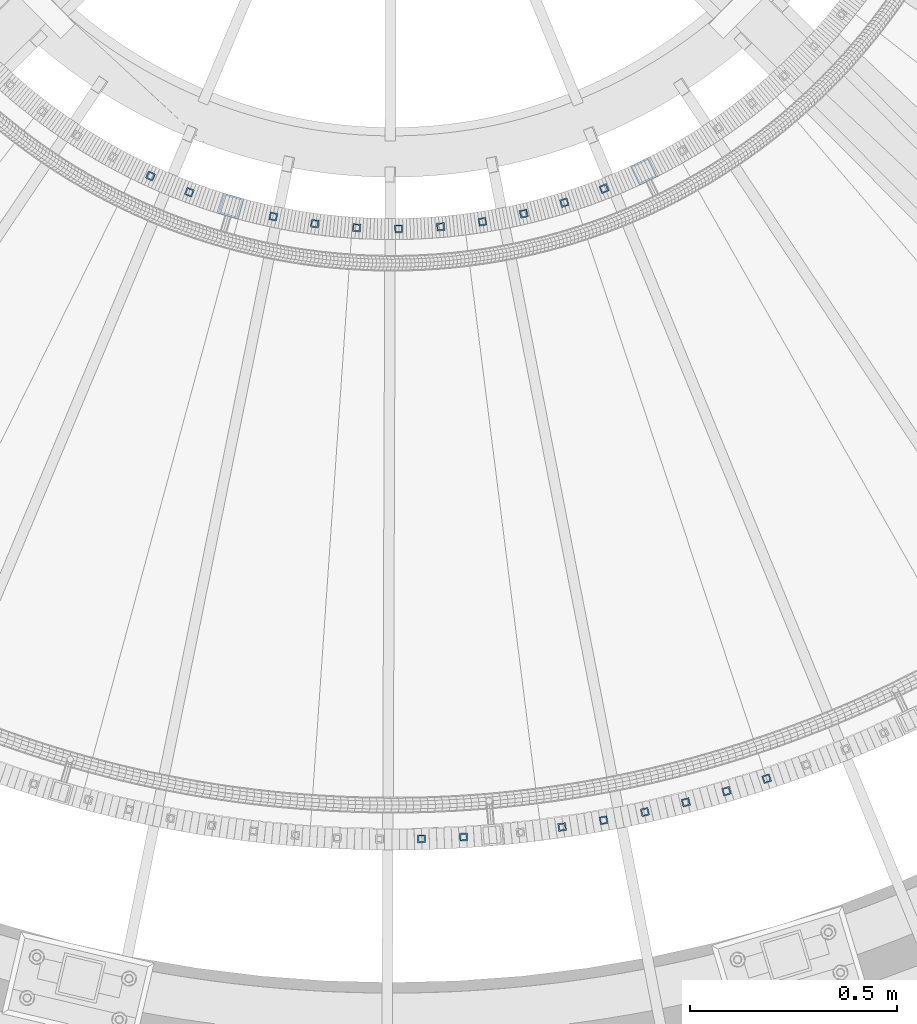
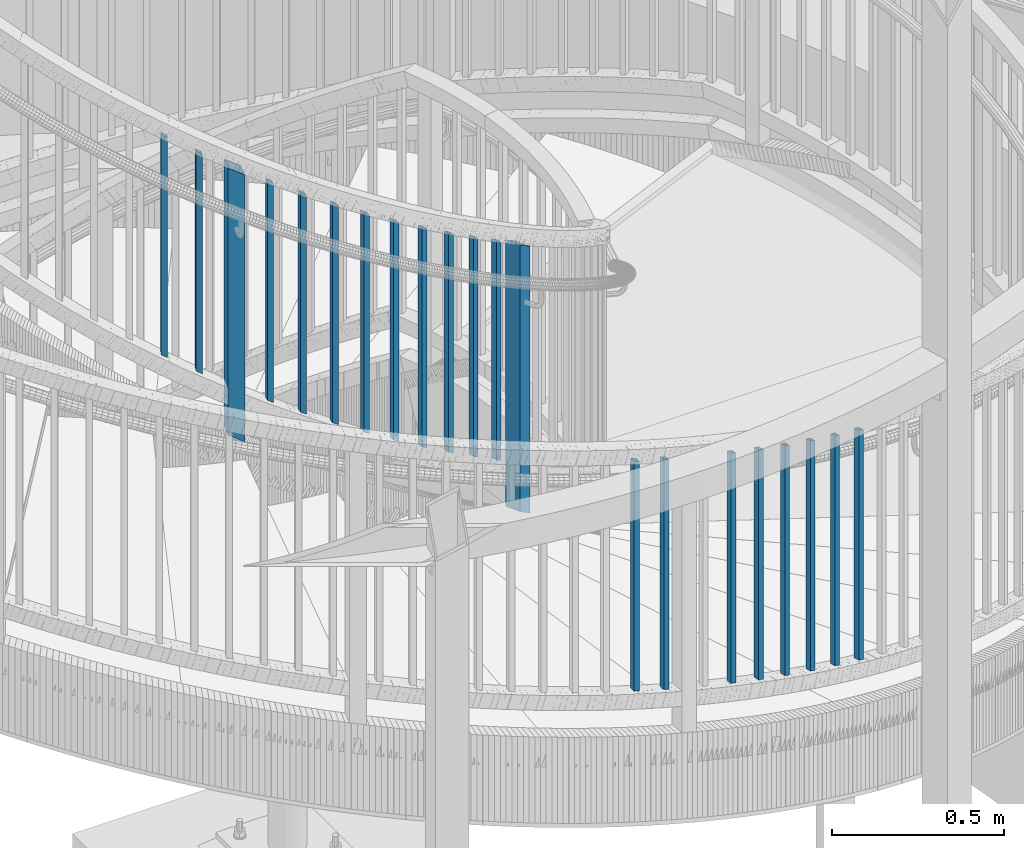
# One storey, part 255 of 975: 21 columns.
"""IFC2X3 building model written with IfcOpenShell, lengths in millimetres."""

from ifc_helpers import new_model, si_unit, frame, origin_with_axes, place, context, subcontext, project, spatial, faceted_brep, material, type_object, element, save


model = new_model("IFC2X3")

# Units and contexts
model_context = context("Model", 3, precision=1e-05, world=origin_with_axes())
body_context = subcontext(model_context, "Body", "Model", "MODEL_VIEW")
ifc_project = project(units=[si_unit("LENGTHUNIT", "METRE", prefix="MILLI"), si_unit("AREAUNIT", "SQUARE_METRE"), si_unit("VOLUMEUNIT", "CUBIC_METRE"), si_unit("MASSUNIT", "GRAM", prefix="KILO"), si_unit("TIMEUNIT", "SECOND"), si_unit("PLANEANGLEUNIT", "RADIAN"), si_unit("SOLIDANGLEUNIT", "STERADIAN"), si_unit("THERMODYNAMICTEMPERATUREUNIT", "DEGREE_CELSIUS"), si_unit("LUMINOUSINTENSITYUNIT", "LUMEN")], contexts=[model_context])

# Site, building, storey
site_placement = place(None, origin_with_axes())
site = spatial("IfcSite", under=ifc_project, at=site_placement, CompositionType="ELEMENT")
building_placement = place(site_placement, origin_with_axes())
building = spatial("IfcBuilding", under=site, at=building_placement, Name="Undefined", CompositionType="ELEMENT")
storey_placement = place(building_placement, origin_with_axes())
storey = spatial("IfcBuildingStorey", under=building, at=storey_placement, Name="Undefined", CompositionType="ELEMENT", Elevation=0.0)

# Columns
ifc_material = material()
column_type_1 = type_object("IfcColumnType", Name="HSS3/4X3/4X.120_TUBES", PredefinedType="NOTDEFINED")
for number, where, z_axis, x_axis, name in (
    (1, (35144.9643289316, 562.901657561375, 3337.39164894143), (0.143220383051681, -0.989690821357119, 0.0), (0.0, 0.0, 1.0), "PICKET"),
    (2, (35245.2335476034, 579.206387144743, 3305.04633694143), (0.178153742922325, -0.984002664570969, 0.0), (0.0, 0.0, 1.0), "PICKET"),
    (3, (35344.8629729798, 599.049220083398, 3272.70102494143), (0.212863934010035, -0.977081852046067, 0.0), (0.0, 0.0, 1.0), "PICKET"),
    (4, (35443.7277997918, 622.405299362534, 3240.35571294143), (0.247307468904138, -0.968937054624411, 0.0), (0.0, 0.0, 1.0), "PICKET"),
    (5, (35541.7041805792, 649.245366941756, 3208.01040094143), (0.281441202939575, -0.959578474793972, 0.0), (0.0, 0.0, 1.0), "PICKET"),
    (6, (35638.6693808336, 679.535800406401, 3175.66508894143), (0.315222376998791, -0.94901783599637, 0.0), (0.0, 0.0, 1.0), "PICKET"),
    (7, (34805.5238669478, 534.391312574778, 3445.4743533963), (0.0249607509979396, -0.999688431917474, 0.0), (0.0, 0.0, 1.0), "PICKET"),
    (8, (34907.0146141472, 538.70181882481, 3413.1290413963), (0.0603219780248401, -0.998178971411025, 0.0), (0.0, 0.0, 1.0), "PICKET"),
):
    element("IfcColumn", number, at=place(storey_placement, frame(where, z_axis=z_axis, x_axis=x_axis)), inside=storey, type_object=column_type_1, material=ifc_material, Name=name, ObjectType="HSS3/4X3/4X.120_TUBES", context=body_context, shape_type="Brep", body=[
        faceted_brep([(48.9778304891588, 6.35000000000036, -6.34999999999854), (44.9444858438005, -6.35000000000582, -6.34999999999127), (858.946568247068, -6.35000000000582, -6.34999999999127), (863.063419332087, 6.35000000000036, -6.34999999999854), (44.9444858438051, -6.35000000000036, 6.35000000000582), (858.946568247072, -6.35000000000036, 6.35000000000582), (48.9778304891634, 6.350000000004, 6.34999999999854), (863.063419332091, 6.350000000004, 6.34999999999854), (49.9861666504976, 9.52499999999964, -9.52500000000146), (49.9861666505039, 9.52500000000691, 9.52499999999418), (864.092632103347, 9.52500000000691, 9.52499999999418), (864.09263210334, 9.52499999999964, -9.52500000000146), (43.9361496824667, -9.52500000000146, 9.52500000001601), (857.917355475819, -9.52500000000146, 9.52500000001601), (43.9361496824599, -9.52500000000691, -9.52499999997963), (857.917355475812, -9.52500000000691, -9.52499999997963)], [[[0, 1, 2, 3]], [[1, 4, 5, 2]], [[4, 6, 7, 5]], [[6, 0, 3, 7]], [[8, 9, 10, 11]], [[9, 12, 13, 10]], [[12, 14, 15, 13]], [[14, 8, 11, 15]], [[13, 15, 11, 10], [5, 7, 3, 2]], [[14, 12, 9, 8], [6, 4, 1, 0]]]),
    ])
for number, where, z_axis, x_axis, name in (
    (9, (34151.3013327036, 2134.41004199642, 3860.961936045), (-0.417534057904537, -0.908661273792259, 0.0), (0.0, 0.0, 1.0), "PICKET"),
    (10, (34245.067153272, 2095.38773828754, 3794.286936045), (-0.350403548031049, -0.936598822082994, 0.0), (0.0, 0.0, 1.0), "PICKET"),
    (11, (34447.7209071227, 2036.58807906212, 3656.38992130595), (-0.205316034013806, -0.978695727065793, 0.0), (0.0, 0.0, 1.0), "PICKET"),
    (12, (34547.8112533657, 2019.36333283445, 3589.71492130595), (-0.133657554974401, -0.991027576810184, 0.0), (0.0, 0.0, 1.0), "PICKET"),
    (13, (34648.8886252272, 2009.45706253692, 3523.03992130595), (-0.0612924279789586, -0.998119851657327, 0.0), (0.0, 0.0, 1.0), "PICKET"),
    (14, (34750.4186254247, 2006.92164273992, 3456.36492130595), (0.0113967529988804, -0.999935054901608, 0.0), (0.0, 0.0, 1.0), "PICKET"),
    (15, (34851.864463624, 2011.77047823845, 3389.68992130595), (0.0840256800377174, -0.996463589447301, 0.0), (0.0, 0.0, 1.0), "PICKET"),
    (16, (34952.6897944563, 2023.97793318084, 3323.80867130595), (0.156210361995181, -0.987723808969559, 0.0), (0.0, 0.0, 1.0), "PICKET"),
    (17, (35052.3615531832, 2043.47946660574, 3257.13367130595), (0.227569156999169, -0.973761920996446, 0.0), (0.0, 0.0, 1.0), "PICKET"),
    (18, (35150.3527740154, 2070.171973671, 3192.04617130595), (0.297724791959052, -0.954651741868698, 0.0), (0.0, 0.0, 1.0), "PICKET"),
    (19, (35246.145376188, 2103.91433077023, 3125.37117130595), (0.366306351865206, -0.930494307657604, 0.0), (0.0, 0.0, 1.0), "PICKET"),
):
    element("IfcColumn", number, at=place(storey_placement, frame(where, z_axis=z_axis, x_axis=x_axis)), inside=storey, type_object=column_type_1, material=ifc_material, Name=name, ObjectType="HSS3/4X3/4X.120_TUBES", context=body_context, shape_type="Brep", body=[
        faceted_brep([(81.3030822565961, 6.34999999999491, -6.34999999997672), (73.0243810963957, -6.34999999999854, -6.35000000000582), (849.31820965341, -6.34999999999854, -6.35000000000582), (857.556470281766, 6.34999999999491, -6.34999999997672), (73.0243810963952, -6.34999999999127, 6.34999999998399), (849.318209653409, -6.34999999999127, 6.34999999998399), (81.3030822565956, 6.35000000000218, 6.34999999999854), (857.556470281765, 6.35000000000218, 6.34999999999854), (83.3727575466464, 9.52499999999054, -9.52499999997235), (83.3727575466455, 9.52500000000509, 9.52500000000146), (859.616035438854, 9.52500000000509, 9.52500000000146), (859.616035438854, 9.52499999999054, -9.52499999997235), (70.9547058063449, -9.5249999999869, 9.52499999997235), (847.25864449632, -9.5249999999869, 9.52499999997235), (70.9547058063458, -9.52500000000146, -9.52499999999418), (847.258644496321, -9.52500000000146, -9.52499999999418)], [[[0, 1, 2, 3]], [[1, 4, 5, 2]], [[4, 6, 7, 5]], [[6, 0, 3, 7]], [[8, 9, 10, 11]], [[9, 12, 13, 10]], [[12, 14, 15, 13]], [[14, 8, 11, 15]], [[13, 15, 11, 10], [5, 7, 3, 2]], [[14, 12, 9, 8], [6, 4, 1, 0]]]),
    ])
column_type_2 = type_object("IfcColumnType", Name="HSS2X2X.188_TUBES", PredefinedType="NOTDEFINED")
column_1_placement = place(storey_placement, frame((35342.9592033706, 2146.06813247641, 2904.07984138255), z_axis=(0.435547032080205, -0.900165975165761, 0.0), x_axis=(0.0, 0.0, 1.0)))
element("IfcColumn", 20, at=column_1_placement, inside=storey, type_object=column_type_2, material=ifc_material, Name="HANDRAIL", ObjectType="HSS2X2X.188_TUBES", context=body_context, shape_type="Brep", body=[
    faceted_brep([(73.8216023003633, 20.6375000000298, -20.6375000000116), (46.7511421721683, -20.6375000000044, -20.6374999999971), (991.653317693376, -20.6375000000044, -20.6374999999971), (1018.78995571227, 20.6375000000298, -20.6375000000116), (46.7511421721192, -20.6375000000262, 20.6375000000116), (991.653317693327, -20.6375000000262, 20.6375000000116), (73.8216023003142, 20.6375000000044, 20.6374999999953), (1018.78995571223, 20.6375000000044, 20.6374999999953), (76.9451169305453, 25.4000000000306, -25.4000000000124), (76.9451169304848, 25.4000000000051, 25.3999999999942), (1021.92110625286, 25.4000000000051, 25.3999999999942), (1021.92110625292, 25.4000000000306, -25.4000000000124), (43.6276275419368, -25.4000000000306, 25.4000000000124), (988.522167152679, -25.4000000000306, 25.4000000000124), (43.6276275419978, -25.4000000000015, -25.399999999996), (988.52216715274, -25.4000000000015, -25.399999999996)], [[[0, 1, 2, 3]], [[1, 4, 5, 2]], [[4, 6, 7, 5]], [[6, 0, 3, 7]], [[8, 9, 10, 11]], [[9, 12, 13, 10]], [[12, 14, 15, 13]], [[14, 8, 11, 15]], [[13, 15, 11, 10], [5, 7, 3, 2]], [[14, 12, 9, 8], [6, 4, 1, 0]]]),
])
column_2_placement = place(storey_placement, frame((34345.2176953613, 2061.93376456903, 3572.63988506017), z_axis=(-0.278655884064232, -0.960391013221376, 0.0), x_axis=(0.0, 0.0, 1.0)))
element("IfcColumn", 21, at=column_2_placement, inside=storey, type_object=column_type_2, material=ifc_material, Name="HANDRAIL", ObjectType="HSS2X2X.188_TUBES", context=body_context, shape_type="Brep", body=[
    faceted_brep([(73.5720581152354, 20.6374999999316, -20.6375000000244), (47.1200722513227, -20.6375000000553, -20.6375000000135), (993.28522860029, -20.6375000000553, -20.6375000000135), (1019.69913264463, 20.6374999999316, -20.6375000000244), (47.1200722513299, -20.6374999999389, 20.6375000000189), (993.285228600298, -20.6374999999389, 20.6375000000189), (73.5720581152427, 20.6375000000444, 20.637500000008), (1019.69913264464, 20.6375000000444, 20.637500000008), (76.6242103303016, 25.3999999999105, -25.4000000000324), (76.6242103303107, 25.400000000056, 25.4000000000106), (1022.7468908036, 25.400000000056, 25.4000000000106), (1022.74689080359, 25.3999999999105, -25.4000000000324), (44.0679200362638, -25.3999999999178, 25.4000000000251), (990.237470441336, -25.3999999999178, 25.4000000000251), (44.0679200362551, -25.4000000000633, -25.400000000016), (990.237470441326, -25.4000000000633, -25.400000000016)], [[[0, 1, 2, 3]], [[1, 4, 5, 2]], [[4, 6, 7, 5]], [[6, 0, 3, 7]], [[8, 9, 10, 11]], [[9, 12, 13, 10]], [[12, 14, 15, 13]], [[14, 8, 11, 15]], [[13, 15, 11, 10], [5, 7, 3, 2]], [[14, 12, 9, 8], [6, 4, 1, 0]]]),
])

save(model, "model.ifc")
